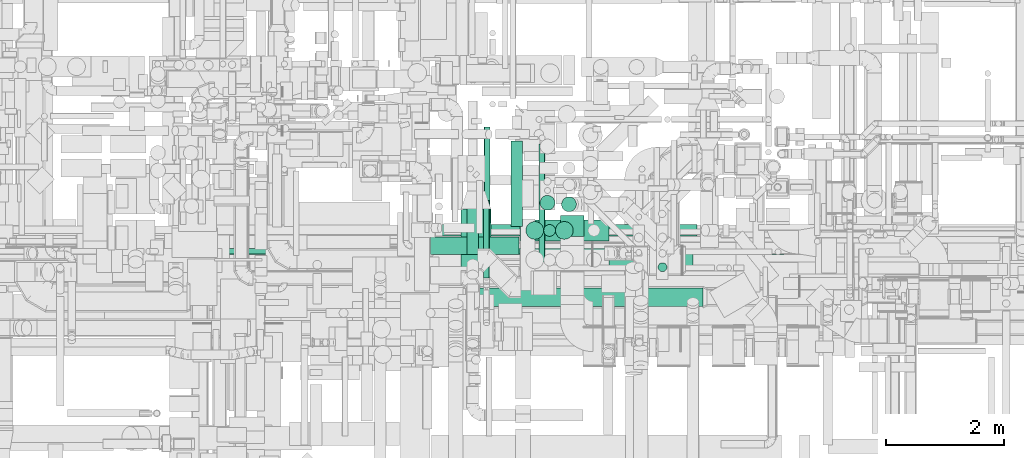
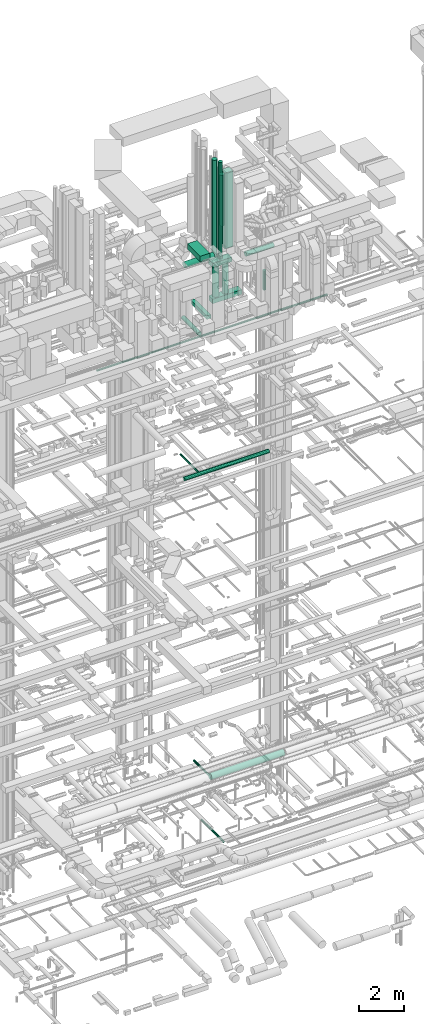
# One storey, part 51 of 337: 20 flow segments.
"""IFC2X3 building model written with IfcOpenShell, lengths in millimetres."""

from ifc_helpers import new_model, entity, si_unit, converted_unit, derived_unit, direction, frame, origin, origin_2d_with_axis, place, context, subcontext, project, spatial, rectangle, circle, extrude, type_object, element, save


model = new_model("IFC2X3")

# Units and contexts
model_context = context("Model", 3, precision=0.01, world=origin(), true_north=direction((6.12303176911189e-17, 1.0)))
body_context = subcontext(model_context, "Body", "Model", "MODEL_VIEW")
ifc_project = project(units=[si_unit("LENGTHUNIT", "METRE", prefix="MILLI"), si_unit("AREAUNIT", "SQUARE_METRE"), si_unit("VOLUMEUNIT", "CUBIC_METRE"), converted_unit("PLANEANGLEUNIT", "DEGREE", entity("IfcRatioMeasure", 0.0174532925199433), si_unit("PLANEANGLEUNIT", "RADIAN"), dimensions=[0, 0, 0, 0, 0, 0, 0]), si_unit("MASSUNIT", "GRAM", prefix="KILO"), derived_unit("MASSDENSITYUNIT", [(si_unit("MASSUNIT", "GRAM", prefix="KILO"), 1), (si_unit("LENGTHUNIT", "METRE"), -3)]), derived_unit("MOMENTOFINERTIAUNIT", [(si_unit("LENGTHUNIT", "METRE"), 4)]), si_unit("TIMEUNIT", "SECOND"), si_unit("FREQUENCYUNIT", "HERTZ"), si_unit("THERMODYNAMICTEMPERATUREUNIT", "DEGREE_CELSIUS"), derived_unit("THERMALTRANSMITTANCEUNIT", [(si_unit("MASSUNIT", "GRAM", prefix="KILO"), 1), (si_unit("THERMODYNAMICTEMPERATUREUNIT", "KELVIN"), -1), (si_unit("TIMEUNIT", "SECOND"), -3)]), derived_unit("VOLUMETRICFLOWRATEUNIT", [(si_unit("LENGTHUNIT", "METRE"), 3), (si_unit("TIMEUNIT", "SECOND"), -1)]), derived_unit("MASSFLOWRATEUNIT", [(si_unit("MASSUNIT", "GRAM", prefix="KILO"), 1), (si_unit("TIMEUNIT", "SECOND"), -1)]), derived_unit("ROTATIONALFREQUENCYUNIT", [(si_unit("TIMEUNIT", "SECOND"), -1)]), si_unit("ELECTRICCURRENTUNIT", "AMPERE"), si_unit("ELECTRICVOLTAGEUNIT", "VOLT"), si_unit("POWERUNIT", "WATT"), si_unit("FORCEUNIT", "NEWTON", prefix="KILO"), si_unit("ILLUMINANCEUNIT", "LUX"), si_unit("LUMINOUSFLUXUNIT", "LUMEN"), si_unit("LUMINOUSINTENSITYUNIT", "CANDELA"), derived_unit("USERDEFINED", [(si_unit("MASSUNIT", "GRAM", prefix="KILO"), -1), (si_unit("LENGTHUNIT", "METRE"), -2), (si_unit("TIMEUNIT", "SECOND"), 3), (si_unit("LUMINOUSFLUXUNIT", "LUMEN"), 1)]), derived_unit("LINEARVELOCITYUNIT", [(si_unit("LENGTHUNIT", "METRE"), 1), (si_unit("TIMEUNIT", "SECOND"), -1)]), si_unit("PRESSUREUNIT", "PASCAL"), derived_unit("USERDEFINED", [(si_unit("LENGTHUNIT", "METRE"), -2), (si_unit("MASSUNIT", "GRAM", prefix="KILO"), 1), (si_unit("TIMEUNIT", "SECOND"), -2)]), derived_unit("LINEARFORCEUNIT", [(si_unit("MASSUNIT", "GRAM", prefix="KILO"), 1), (si_unit("LENGTHUNIT", "METRE"), 1), (si_unit("TIMEUNIT", "SECOND"), -2), (si_unit("LENGTHUNIT", "METRE"), -1)]), derived_unit("PLANARFORCEUNIT", [(si_unit("MASSUNIT", "GRAM", prefix="KILO"), 1), (si_unit("LENGTHUNIT", "METRE"), 1), (si_unit("TIMEUNIT", "SECOND"), -2), (si_unit("LENGTHUNIT", "METRE"), -2)])], contexts=[model_context])

# Site, building, storey
site_placement = place(None, origin())
site = spatial("IfcSite", under=ifc_project, at=site_placement, CompositionType="ELEMENT")
building_placement = place(site_placement, origin())
building = spatial("IfcBuilding", under=site, at=building_placement, CompositionType="ELEMENT")
storey_placement = place(building_placement, origin())
storey = spatial("IfcBuildingStorey", under=building, at=storey_placement, CompositionType="ELEMENT", Elevation=0.0)

# Flow segments
duct_segment_type_1 = type_object("IfcDuctSegmentType", PredefinedType="NOTDEFINED")
flow_segment_1_placement = place(storey_placement, frame((54977.37, 10302.41, 27450.0)))
element("IfcFlowSegment", 1, at=flow_segment_1_placement, inside=storey, type_object=duct_segment_type_1, context=body_context, shape_type="SweptSolid", body=[
    extrude(rectangle(XDim=1440.92776220451, YDim=199.999999999998, at=origin_2d_with_axis()), frame((100.0, 720.46, 0.0), z_axis=(0.0, 0.0, 1.0), x_axis=(0.0, -1.0, 0.0)), (0.0, 0.0, 1.0), 199.999999999998),
])
flow_segment_2_placement = place(storey_placement, frame((55811.0, 10133.0, 31100.0)))
element("IfcFlowSegment", 2, at=flow_segment_2_placement, inside=storey, type_object=duct_segment_type_1, context=body_context, shape_type="SweptSolid", body=[
    extrude(rectangle(XDim=349.999999999996, YDim=399.999999999996, at=origin_2d_with_axis()), frame((200.0, 175.0, 0.0), z_axis=(0.0, 0.0, 1.0), x_axis=(0.0, -1.0, 0.0)), (0.0, 0.0, 1.0), 4125.16927854901),
])
flow_segment_3_placement = place(storey_placement, frame((54138.0, 9455.5, 31400.0)))
element("IfcFlowSegment", 3, at=flow_segment_3_placement, inside=storey, type_object=duct_segment_type_1, context=body_context, shape_type="SweptSolid", body=[
    extrude(rectangle(XDim=1144.10398499964, YDim=499.999999999999, at=origin_2d_with_axis()), frame((250.0, 572.05, 0.0), z_axis=(0.0, 0.0, 1.0), x_axis=(0.0, 1.0, 0.0)), (0.0, 0.0, 1.0), 300.000000000001),
])
flow_segment_4_placement = place(storey_placement, frame((55133.85, 10059.06, 28400.0)))
element("IfcFlowSegment", 4, at=flow_segment_4_placement, inside=storey, type_object=duct_segment_type_1, context=body_context, shape_type="SweptSolid", body=[
    extrude(rectangle(XDim=1500.0, YDim=350.000000000001, at=origin_2d_with_axis()), frame((750.0, 175.0, 0.0), z_axis=(0.0, 0.0, 1.0), x_axis=(-1.0, 0.0, 0.0)), (0.0, 0.0, 1.0), 250.000000000004),
])
flow_segment_5_placement = place(storey_placement, frame((55128.85, 10059.06, 30352.46)))
element("IfcFlowSegment", 5, at=flow_segment_5_placement, inside=storey, type_object=duct_segment_type_1, context=body_context, shape_type="SweptSolid", body=[
    extrude(rectangle(XDim=999.999999999998, YDim=350.000000000001, at=origin_2d_with_axis()), frame((500.0, 175.0, 0.0)), (0.0, 0.0, 1.0), 250.000000000004),
])
duct_segment_type_2 = type_object("IfcDuctSegmentType", PredefinedType="NOTDEFINED")
flow_segment_6_placement = place(storey_placement, frame((55452.58, 9698.98, -836.6)))
element("IfcFlowSegment", 6, at=flow_segment_6_placement, inside=storey, type_object=duct_segment_type_2, context=body_context, shape_type="SweptSolid", body=[
    extrude(circle(Radius=50.0, at=origin_2d_with_axis()), frame((51.6, 0.0, 51.6), z_axis=(0.0, 1.0, 0.0), x_axis=(1.0, 0.0, 0.0)), (0.0, 0.0, 1.0), 1997.18633000003),
])
flow_segment_7_placement = place(storey_placement, frame((53749.89, 10135.8, 19148.4)))
element("IfcFlowSegment", 7, at=flow_segment_7_placement, inside=storey, type_object=duct_segment_type_2, context=body_context, shape_type="SweptSolid", body=[
    extrude(circle(Radius=100.0, at=origin_2d_with_axis()), frame((0.0, 101.6, 101.6), z_axis=(1.0, 0.0, 0.0), x_axis=(0.0, 1.0, 0.0)), (0.0, 0.0, 1.0), 4367.79595927292),
])
flow_segment_8_placement = place(storey_placement, frame((54525.58, 10357.4, 19198.41)))
element("IfcFlowSegment", 8, at=flow_segment_8_placement, inside=storey, type_object=duct_segment_type_2, context=body_context, shape_type="SweptSolid", body=[
    extrude(circle(Radius=50.0, at=origin_2d_with_axis()), frame((51.6, 0.0, 51.6), z_axis=(0.0, 1.0, 0.0), x_axis=(-1.0, 0.0, 0.0)), (0.0, 0.0, 1.0), 1619.40430537442),
])
flow_segment_9_placement = place(storey_placement, frame((54231.92, 9825.35, 27098.4)))
element("IfcFlowSegment", 9, at=flow_segment_9_placement, inside=storey, type_object=duct_segment_type_2, context=body_context, shape_type="SweptSolid", body=[
    extrude(circle(Radius=100.0, at=origin_2d_with_axis()), frame((101.6, 0.0, 101.6), z_axis=(0.0, 1.0, 0.0), x_axis=(-1.0, 0.0, 0.0)), (0.0, 0.0, 1.0), 1482.42358986801),
])
flow_segment_10_placement = place(storey_placement, frame((53620.03, 9824.0, 30948.4)))
element("IfcFlowSegment", 10, at=flow_segment_10_placement, inside=storey, type_object=duct_segment_type_2, context=body_context, shape_type="SweptSolid", body=[
    extrude(circle(Radius=150.0, at=origin_2d_with_axis()), frame((0.0, 151.6, 151.6), z_axis=(1.0, 0.0, 0.0), x_axis=(0.0, 1.0, 0.0)), (0.0, 0.0, 1.0), 1497.46669999997),
])
flow_segment_11_placement = place(storey_placement, frame((55831.4, 10547.9, 32050.0)))
element("IfcFlowSegment", 11, at=flow_segment_11_placement, inside=storey, type_object=duct_segment_type_2, context=body_context, shape_type="SweptSolid", body=[
    extrude(circle(Radius=125.0, at=origin_2d_with_axis()), frame((126.6, 126.6, 0.0), z_axis=(0.0, 0.0, 1.0), x_axis=(0.0, 1.0, 0.0)), (0.0, 0.0, 1.0), 2770.00000000001),
])
flow_segment_12_placement = place(storey_placement, frame((57459.9, 9536.46, 28620.0)))
element("IfcFlowSegment", 12, at=flow_segment_12_placement, inside=storey, type_object=duct_segment_type_2, context=body_context, shape_type="SweptSolid", body=[
    extrude(circle(Radius=75.0, at=origin_2d_with_axis()), frame((76.6, 76.6, 0.0), z_axis=(0.0, 0.0, 1.0), x_axis=(-1.0, 0.0, 0.0)), (0.0, 0.0, 1.0), 1059.99999999996),
])
flow_segment_13_placement = place(storey_placement, frame((56630.0, 9611.52, 30670.61)))
element("IfcFlowSegment", 13, at=flow_segment_13_placement, inside=storey, type_object=duct_segment_type_2, context=body_context, shape_type="SweptSolid", body=[
    extrude(circle(Radius=125.0, at=origin_2d_with_axis()), frame((0.0, 126.6, 126.6), z_axis=(1.0, 0.0, 0.0), x_axis=(0.0, 0.500000000000003, -0.866025403784437)), (0.0, 0.0, 1.0), 1425.03330999929),
])
for number, where in (
    (14, (55228.4, 10082.47, 28670.0)),
    (15, (55728.4, 10082.47, 28670.0)),
):
    element("IfcFlowSegment", number, at=place(storey_placement, frame(where)), inside=storey, type_object=duct_segment_type_2, context=body_context, shape_type="SweptSolid", body=[
        extrude(circle(Radius=150.0, at=origin_2d_with_axis()), frame((151.6, 151.6, 0.0), z_axis=(0.0, 0.0, 1.0), x_axis=(0.0, 1.0, 0.0)), (0.0, 0.0, 1.0), 1662.46038474583),
    ])
flow_segment_14_placement = place(storey_placement, frame((55529.55, 10132.47, 30622.46)))
element("IfcFlowSegment", 16, at=flow_segment_14_placement, inside=storey, type_object=duct_segment_type_2, context=body_context, shape_type="SweptSolid", body=[
    extrude(circle(Radius=100.0, at=origin_2d_with_axis()), frame((101.6, 101.6, 0.0), z_axis=(0.0, 0.0, 1.0), x_axis=(0.0, -1.0, 0.0)), (0.0, 0.0, 1.0), 5254.99999999996),
])
flow_segment_15_placement = place(storey_placement, frame((55468.43, 10574.01, 30248.56)))
element("IfcFlowSegment", 17, at=flow_segment_15_placement, inside=storey, type_object=duct_segment_type_2, context=body_context, shape_type="SweptSolid", body=[
    extrude(circle(Radius=125.0, at=origin_2d_with_axis()), frame((126.6, 126.6, 0.0), z_axis=(0.0, 0.0, 1.0), x_axis=(-1.0, 0.0, 0.0)), (0.0, 0.0, 1.0), 5500.0),
])
flow_segment_16_placement = place(storey_placement, frame((54446.4, 8949.55, 3340.9)))
element("IfcFlowSegment", 18, at=flow_segment_16_placement, inside=storey, type_object=duct_segment_type_2, context=body_context, shape_type="SweptSolid", body=[
    extrude(circle(Radius=157.5, at=origin_2d_with_axis()), frame((0.0, 159.1, 159.1), z_axis=(1.0, 0.0, 1.07442470087076e-05), x_axis=(0.0, -1.0, 0.0)), (0.0, 0.0, 1.0), 3775.00011162473),
])
flow_segment_17_placement = place(storey_placement, frame((49063.52, 9829.93, 26948.4)))
element("IfcFlowSegment", 19, at=flow_segment_17_placement, inside=storey, type_object=duct_segment_type_2, context=body_context, shape_type="SweptSolid", body=[
    extrude(circle(Radius=50.0, at=origin_2d_with_axis()), frame((0.0, 51.6, 51.6), z_axis=(1.0, 0.0, 0.0), x_axis=(0.0, -1.0, 0.0)), (0.0, 0.0, 1.0), 11864.9330372433),
])
flow_segment_18_placement = place(storey_placement, frame((54515.4, 9428.48, 3288.41)))
element("IfcFlowSegment", 20, at=flow_segment_18_placement, inside=storey, type_object=duct_segment_type_2, context=body_context, shape_type="SweptSolid", body=[
    extrude(circle(Radius=50.0, at=origin_2d_with_axis()), frame((51.6, 0.0, 51.6), z_axis=(0.0, 1.0, 0.0), x_axis=(-1.0, 0.0, 0.0)), (0.0, 0.0, 1.0), 1314.51082506284),
])

save(model, "model.ifc")
